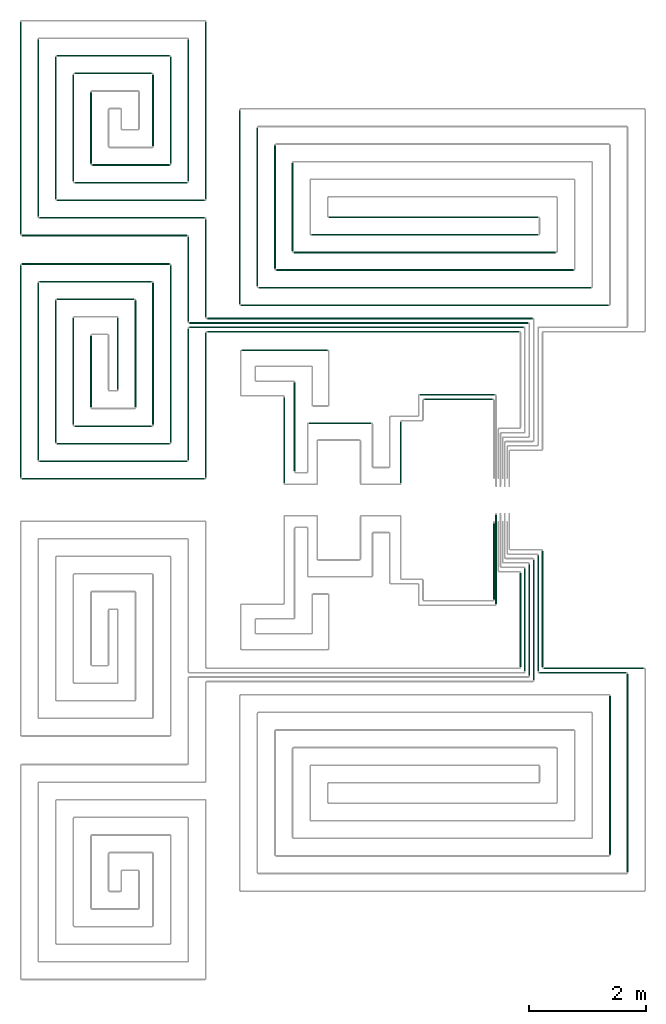
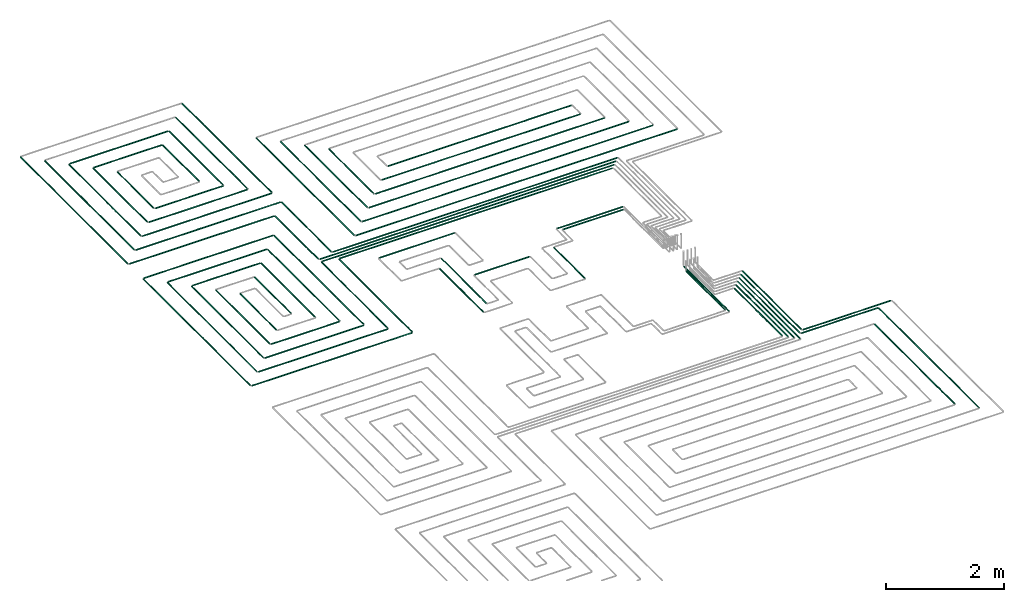
# One storey, part 2 of 12: 69 flow segments.
"""IFC2X3 building model written with IfcOpenShell, lengths in millimetres."""

from ifc_helpers import new_model, entity, si_unit, converted_unit, derived_unit, direction, frame, frame_2d, origin, origin_2d_with_axis, place, context, subcontext, project, spatial, circle, extrude, type_object, element, save


model = new_model("IFC2X3")

# Units and contexts
model_context = context("Model", 3, precision=0.01, world=origin(), true_north=direction((6.12303176911189e-17, 1.0)))
body_context = subcontext(model_context, "Body", "Model", "MODEL_VIEW")
ifc_project = project(units=[si_unit("LENGTHUNIT", "METRE", prefix="MILLI"), si_unit("AREAUNIT", "SQUARE_METRE"), si_unit("VOLUMEUNIT", "CUBIC_METRE"), converted_unit("PLANEANGLEUNIT", "DEGREE", entity("IfcRatioMeasure", 0.0174532925199433), si_unit("PLANEANGLEUNIT", "RADIAN"), dimensions=[0, 0, 0, 0, 0, 0, 0]), si_unit("MASSUNIT", "GRAM", prefix="KILO"), derived_unit("MASSDENSITYUNIT", [(si_unit("MASSUNIT", "GRAM", prefix="KILO"), 1), (si_unit("LENGTHUNIT", "METRE"), -3)]), si_unit("TIMEUNIT", "SECOND"), si_unit("FREQUENCYUNIT", "HERTZ"), si_unit("THERMODYNAMICTEMPERATUREUNIT", "DEGREE_CELSIUS"), derived_unit("THERMALTRANSMITTANCEUNIT", [(si_unit("MASSUNIT", "GRAM", prefix="KILO"), 1), (si_unit("THERMODYNAMICTEMPERATUREUNIT", "KELVIN"), -1), (si_unit("TIMEUNIT", "SECOND"), -3)]), derived_unit("VOLUMETRICFLOWRATEUNIT", [(si_unit("LENGTHUNIT", "METRE"), 3), (si_unit("TIMEUNIT", "SECOND"), -1)]), si_unit("ELECTRICCURRENTUNIT", "AMPERE"), si_unit("ELECTRICVOLTAGEUNIT", "VOLT"), si_unit("POWERUNIT", "WATT"), si_unit("FORCEUNIT", "NEWTON", prefix="KILO"), si_unit("ILLUMINANCEUNIT", "LUX"), si_unit("LUMINOUSFLUXUNIT", "LUMEN"), si_unit("LUMINOUSINTENSITYUNIT", "CANDELA"), derived_unit("USERDEFINED", [(si_unit("MASSUNIT", "GRAM", prefix="KILO"), -1), (si_unit("LENGTHUNIT", "METRE"), -2), (si_unit("TIMEUNIT", "SECOND"), 3), (si_unit("LUMINOUSFLUXUNIT", "LUMEN"), 1)]), derived_unit("LINEARVELOCITYUNIT", [(si_unit("LENGTHUNIT", "METRE"), 1), (si_unit("TIMEUNIT", "SECOND"), -1)]), si_unit("PRESSUREUNIT", "PASCAL"), derived_unit("USERDEFINED", [(si_unit("LENGTHUNIT", "METRE"), -2), (si_unit("MASSUNIT", "GRAM", prefix="KILO"), 1), (si_unit("TIMEUNIT", "SECOND"), -2)])], contexts=[model_context])

# Site, building, storey
site_placement = place(None, origin())
site = spatial("IfcSite", under=ifc_project, at=site_placement, CompositionType="ELEMENT")
building_placement = place(site_placement, origin())
building = spatial("IfcBuilding", under=site, at=building_placement, CompositionType="ELEMENT")
storey_placement = place(building_placement, frame((0.0, 0.0, 12000.0)))
storey = spatial("IfcBuildingStorey", under=building, at=storey_placement, Name="03 Level", CompositionType="ELEMENT", Elevation=12000.0)

# Flow segments
pipe_segment_type = type_object("IfcPipeSegmentType", PredefinedType="NOTDEFINED")
flow_segment_1_placement = place(storey_placement, frame((26623.6855494475, -71711.6450070283, -81.5952722359161)))
element("IfcFlowSegment", 1, at=flow_segment_1_placement, inside=storey, type_object=pipe_segment_type, context=body_context, shape_type="SweptSolid", body=[
    extrude(circle(Radius=10.0, at=origin_2d_with_axis()), frame((0.0, 11.5952722359136, 11.5952722359158), z_axis=(1.0, 0.0, 0.0), x_axis=(0.0, -1.0, 0.0)), (0.0, 0.0, 1.0), 1709.41153197237),
])
flow_segment_2_placement = place(storey_placement, frame((26548.6855494475, -71786.6450070283, -81.5952722359143)))
element("IfcFlowSegment", 2, at=flow_segment_2_placement, inside=storey, type_object=pipe_segment_type, context=body_context, shape_type="SweptSolid", body=[
    extrude(circle(Radius=10.0, at=origin_2d_with_axis()), frame((0.0, 11.5952722359136, 11.5952722359158), z_axis=(1.0, 0.0, 0.0), x_axis=(0.0, -1.0, 0.0)), (0.0, 0.0, 1.0), 1484.41153197236),
])
flow_segment_3_placement = place(storey_placement, frame((28041.5018091839, -75179.8436457933, -81.5952722359198)))
element("IfcFlowSegment", 3, at=flow_segment_3_placement, inside=storey, type_object=pipe_segment_type, context=body_context, shape_type="SweptSolid", body=[
    extrude(circle(Radius=10.0, at=frame_2d((-2.59888111031614e-11, 0.0), x_axis=(1.0, 0.0))), frame((11.5952722359526, 0.0, 11.5952722359158), z_axis=(0.0, 1.0, 0.0), x_axis=(-1.0, 0.0, 0.0)), (0.0, 0.0, 1.0), 3384.79391100087),
])
flow_segment_4_placement = place(storey_placement, frame((27741.5018091839, -74879.8436457933, -81.5952722359198)))
element("IfcFlowSegment", 4, at=flow_segment_4_placement, inside=storey, type_object=pipe_segment_type, context=body_context, shape_type="SweptSolid", body=[
    extrude(circle(Radius=10.0, at=origin_2d_with_axis()), frame((11.5952722359223, 0.0, 11.5952722359158), z_axis=(0.0, 1.0, 0.0), x_axis=(1.0, 0.0, 0.0)), (0.0, 0.0, 1.0), 2707.85893213088),
])
flow_segment_5_placement = place(storey_placement, frame((26442.0902772116, -71905.0497347924, -81.5952722359198)))
element("IfcFlowSegment", 5, at=flow_segment_5_placement, inside=storey, type_object=pipe_segment_type, context=body_context, shape_type="SweptSolid", body=[
    extrude(circle(Radius=10.0, at=origin_2d_with_axis()), frame((11.595272235918, 0.0, 11.5952722359158), z_axis=(0.0, 1.0, 0.0), x_axis=(-1.0, 0.0, 0.0)), (0.0, 0.0, 1.0), 2056.31014965248),
])
flow_segment_6_placement = place(storey_placement, frame((26367.0902772116, -71830.0497347924, -81.5952722359161)))
element("IfcFlowSegment", 6, at=flow_segment_6_placement, inside=storey, type_object=pipe_segment_type, context=body_context, shape_type="SweptSolid", body=[
    extrude(circle(Radius=10.0, at=origin_2d_with_axis()), frame((11.5952722359266, 0.0, 11.5952722359158), z_axis=(0.0, 1.0, 0.0), x_axis=(1.0, 0.0, 0.0)), (0.0, 0.0, 1.0), 1906.31014965249),
])
flow_segment_7_placement = place(storey_placement, frame((26292.0902772116, -71755.0497347924, -81.5952722359161)))
element("IfcFlowSegment", 7, at=flow_segment_7_placement, inside=storey, type_object=pipe_segment_type, context=body_context, shape_type="SweptSolid", body=[
    extrude(circle(Radius=10.0, at=origin_2d_with_axis()), frame((11.595272235918, 0.0, 11.5952722359158), z_axis=(0.0, 1.0, 0.0), x_axis=(1.0, 0.0, 0.0)), (0.0, 0.0, 1.0), 1756.31014965249),
])
flow_segment_8_placement = place(storey_placement, frame((26217.0902772116, -71680.0497347924, -81.5952722359198)))
element("IfcFlowSegment", 8, at=flow_segment_8_placement, inside=storey, type_object=pipe_segment_type, context=body_context, shape_type="SweptSolid", body=[
    extrude(circle(Radius=10.0, at=frame_2d((-4.33146851719357e-12, 0.0), x_axis=(1.0, 0.0))), frame((11.595272235918, 0.0, 11.5952722359158), z_axis=(0.0, 1.0, 0.0), x_axis=(-1.0, 0.0, 0.0)), (0.0, 0.0, 1.0), 1606.3101496525),
])
flow_segment_9_placement = place(storey_placement, frame((26592.0902772116, -71680.0497347924, -81.5952722359198)))
element("IfcFlowSegment", 9, at=flow_segment_9_placement, inside=storey, type_object=pipe_segment_type, context=body_context, shape_type="SweptSolid", body=[
    extrude(circle(Radius=10.0, at=frame_2d((4.33146851719357e-12, 0.0), x_axis=(1.0, 0.0))), frame((11.5952722359266, 0.0, 11.5952722359158), z_axis=(0.0, 1.0, 0.0), x_axis=(-1.0, 0.0, 0.0)), (0.0, 0.0, 1.0), 1981.31014965248),
])
flow_segment_10_placement = place(storey_placement, frame((26517.0902772116, -71755.0497347924, -81.5952722359161)))
element("IfcFlowSegment", 10, at=flow_segment_10_placement, inside=storey, type_object=pipe_segment_type, context=body_context, shape_type="SweptSolid", body=[
    extrude(circle(Radius=10.0, at=origin_2d_with_axis()), frame((11.5952722359266, 0.0, 11.5952722359158), z_axis=(0.0, 1.0, 0.0), x_axis=(1.0, 0.0, 0.0)), (0.0, 0.0, 1.0), 1981.31014965249),
])
flow_segment_11_placement = place(storey_placement, frame((25764.4416997349, -70531.3143518619, -81.5952722359252)))
element("IfcFlowSegment", 11, at=flow_segment_11_placement, inside=storey, type_object=pipe_segment_type, context=body_context, shape_type="SweptSolid", body=[
    extrude(circle(Radius=10.0, at=origin_2d_with_axis()), frame((11.595272235918, 0.0, 11.5952722359158), z_axis=(0.0, 1.0, 0.0), x_axis=(1.0, 0.0, 0.0)), (0.0, 0.0, 1.0), 1305.07476672193),
])
flow_segment_12_placement = place(storey_placement, frame((25799.4416997349, -70606.3143518619, -81.5952722359289)))
element("IfcFlowSegment", 12, at=flow_segment_12_placement, inside=storey, type_object=pipe_segment_type, context=body_context, shape_type="SweptSolid", body=[
    extrude(circle(Radius=10.0, at=frame_2d((0.0, -2.16573425859679e-12), x_axis=(1.0, 0.0))), frame((11.595272235918, 0.0, 11.5952722359136), z_axis=(0.0, 1.0, 0.0), x_axis=(1.0, 0.0, 0.0)), (0.0, 0.0, 1.0), 1520.07476672191),
])
flow_segment_13_placement = place(storey_placement, frame((20884.4386293741, -65974.0247077234, -81.5952722359198)))
element("IfcFlowSegment", 13, at=flow_segment_13_placement, inside=storey, type_object=pipe_segment_type, context=body_context, shape_type="SweptSolid", body=[
    extrude(circle(Radius=10.0, at=frame_2d((-8.66293703438714e-12, 0.0), x_axis=(1.0, 0.0))), frame((0.0, 11.595272235931, 11.5952722359158), z_axis=(1.0, 0.0, 0.0), x_axis=(0.0, 1.0, 0.0)), (0.0, 0.0, 1.0), 5324.24692007345),
])
flow_segment_14_placement = place(storey_placement, frame((20584.4386293741, -65899.0247077234, -81.5952722359161)))
element("IfcFlowSegment", 14, at=flow_segment_14_placement, inside=storey, type_object=pipe_segment_type, context=body_context, shape_type="SweptSolid", body=[
    extrude(circle(Radius=10.0, at=frame_2d((-8.66293703438714e-12, -2.16573425859679e-12), x_axis=(1.0, 0.0))), frame((0.0, 11.5952722359223, 11.595272235918), z_axis=(1.0, 0.0, 0.0), x_axis=(0.0, 1.0, 0.0)), (0.0, 0.0, 1.0), 5699.24692007345),
])
flow_segment_15_placement = place(storey_placement, frame((20584.4386293741, -65824.0247077234, -81.5952722359161)))
element("IfcFlowSegment", 15, at=flow_segment_15_placement, inside=storey, type_object=pipe_segment_type, context=body_context, shape_type="SweptSolid", body=[
    extrude(circle(Radius=10.0, at=frame_2d((8.66293703438714e-12, -2.16573425859679e-12), x_axis=(1.0, 0.0))), frame((0.0, 11.595272235905, 11.595272235918), z_axis=(1.0, 0.0, 0.0), x_axis=(0.0, 1.0, 0.0)), (0.0, 0.0, 1.0), 5774.24692007345),
])
flow_segment_16_placement = place(storey_placement, frame((20884.4386293741, -65749.0247077234, -81.5952722359161)))
element("IfcFlowSegment", 16, at=flow_segment_16_placement, inside=storey, type_object=pipe_segment_type, context=body_context, shape_type="SweptSolid", body=[
    extrude(circle(Radius=10.0, at=frame_2d((0.0, -2.16573425859679e-12), x_axis=(1.0, 0.0))), frame((0.0, 11.5952722359136, 11.595272235918), z_axis=(1.0, 0.0, 0.0), x_axis=(0.0, 1.0, 0.0)), (0.0, 0.0, 1.0), 5549.24692007344),
])
flow_segment_17_placement = place(storey_placement, frame((20552.8433571382, -65792.4294354875, -81.5952722359198)))
element("IfcFlowSegment", 17, at=flow_segment_17_placement, inside=storey, type_object=pipe_segment_type, context=body_context, shape_type="SweptSolid", body=[
    extrude(circle(Radius=10.0, at=origin_2d_with_axis()), frame((11.595272235918, 0.0, 11.5952722359158), z_axis=(0.0, 1.0, 0.0), x_axis=(1.0, 0.0, 0.0)), (0.0, 0.0, 1.0), 1451.18985034759),
])
flow_segment_18_placement = place(storey_placement, frame((20852.8433571382, -65717.4294354875, -81.5952722359198)))
element("IfcFlowSegment", 18, at=flow_segment_18_placement, inside=storey, type_object=pipe_segment_type, context=body_context, shape_type="SweptSolid", body=[
    extrude(circle(Radius=10.0, at=origin_2d_with_axis()), frame((11.5952722359223, 0.0, 11.5952722359158), z_axis=(0.0, 1.0, 0.0), x_axis=(1.0, 0.0, 0.0)), (0.0, 0.0, 1.0), 1676.18985034759),
])
flow_segment_19_placement = place(storey_placement, frame((24586.730888343, -67122.7600906539, -81.595272235927)))
element("IfcFlowSegment", 19, at=flow_segment_19_placement, inside=storey, type_object=pipe_segment_type, context=body_context, shape_type="SweptSolid", body=[
    extrude(circle(Radius=10.0, at=origin_2d_with_axis()), frame((0.0, 11.5952722359483, 11.5952722359158), z_axis=(1.0, 0.0, 0.0), x_axis=(0.0, -1.0, 0.0)), (0.0, 0.0, 1.0), 1169.30608362779),
])
flow_segment_20_placement = place(storey_placement, frame((20852.8433571382, -68451.2395851399, -81.5952722359198)))
element("IfcFlowSegment", 20, at=flow_segment_20_placement, inside=storey, type_object=pipe_segment_type, context=body_context, shape_type="SweptSolid", body=[
    extrude(circle(Radius=10.0, at=origin_2d_with_axis()), frame((11.5952722359439, 0.0, 11.5952722359158), z_axis=(0.0, 1.0, 0.0), x_axis=(1.0, 0.0, 0.0)), (0.0, 0.0, 1.0), 2468.81014965244),
])
flow_segment_21_placement = place(storey_placement, frame((20552.8433571382, -68151.2395851399, -81.5952722359198)))
element("IfcFlowSegment", 21, at=flow_segment_21_placement, inside=storey, type_object=pipe_segment_type, context=body_context, shape_type="SweptSolid", body=[
    extrude(circle(Radius=10.0, at=frame_2d((8.66293703438714e-12, 0.0), x_axis=(1.0, 0.0))), frame((11.5952722359266, 0.0, 11.5952722359158), z_axis=(0.0, 1.0, 0.0), x_axis=(-1.0, 0.0, 0.0)), (0.0, 0.0, 1.0), 2243.81014965244),
])
flow_segment_22_placement = place(storey_placement, frame((17725.6253473195, -68482.8348573758, -81.5952722359198)))
element("IfcFlowSegment", 22, at=flow_segment_22_placement, inside=storey, type_object=pipe_segment_type, context=body_context, shape_type="SweptSolid", body=[
    extrude(circle(Radius=10.0, at=frame_2d((1.73258740687743e-11, 0.0), x_axis=(1.0, 0.0))), frame((0.0, 11.595272235931, 11.5952722359158), z_axis=(1.0, 0.0, 0.0), x_axis=(0.0, 1.0, 0.0)), (0.0, 0.0, 1.0), 3118.81328205467),
])
flow_segment_23_placement = place(storey_placement, frame((18025.6253473195, -68182.8348573758, -81.5952722359198)))
element("IfcFlowSegment", 23, at=flow_segment_23_placement, inside=storey, type_object=pipe_segment_type, context=body_context, shape_type="SweptSolid", body=[
    extrude(circle(Radius=10.0, at=frame_2d((8.66293703438714e-12, 0.0), x_axis=(1.0, 0.0))), frame((0.0, 11.5952722359223, 11.5952722359158), z_axis=(1.0, 0.0, 0.0), x_axis=(0.0, 1.0, 0.0)), (0.0, 0.0, 1.0), 2518.81328205467),
])
flow_segment_24_placement = place(storey_placement, frame((17994.0300750835, -68151.2395851399, -81.5952722359198)))
element("IfcFlowSegment", 24, at=flow_segment_24_placement, inside=storey, type_object=pipe_segment_type, context=body_context, shape_type="SweptSolid", body=[
    extrude(circle(Radius=10.0, at=origin_2d_with_axis()), frame((11.5952722359439, 0.0, 11.5952722359158), z_axis=(0.0, 1.0, 0.0), x_axis=(1.0, 0.0, 0.0)), (0.0, 0.0, 1.0), 3023.35825128324),
])
flow_segment_25_placement = place(storey_placement, frame((17694.0300750835, -68451.2395851399, -81.5952722359216)))
element("IfcFlowSegment", 25, at=flow_segment_25_placement, inside=storey, type_object=pipe_segment_type, context=body_context, shape_type="SweptSolid", body=[
    extrude(circle(Radius=10.0, at=frame_2d((0.0, -2.16573425859679e-12), x_axis=(1.0, 0.0))), frame((11.5952722359374, 0.0, 11.5952722359136), z_axis=(0.0, 1.0, 0.0), x_axis=(1.0, 0.0, 0.0)), (0.0, 0.0, 1.0), 3623.35825128323),
])
flow_segment_26_placement = place(storey_placement, frame((18025.6253473194, -65119.4766060926, -81.5952722359198)))
element("IfcFlowSegment", 26, at=flow_segment_26_placement, inside=storey, type_object=pipe_segment_type, context=body_context, shape_type="SweptSolid", body=[
    extrude(circle(Radius=10.0, at=frame_2d((8.66293703438714e-12, 0.0), x_axis=(1.0, 0.0))), frame((0.0, 11.595272235905, 11.5952722359158), z_axis=(1.0, 0.0, 0.0), x_axis=(0.0, 1.0, 0.0)), (0.0, 0.0, 1.0), 1918.81328205468),
])
flow_segment_27_placement = place(storey_placement, frame((17725.6253473194, -64819.4766060926, -81.5952722359198)))
element("IfcFlowSegment", 27, at=flow_segment_27_placement, inside=storey, type_object=pipe_segment_type, context=body_context, shape_type="SweptSolid", body=[
    extrude(circle(Radius=10.0, at=frame_2d((8.66293703438714e-12, 0.0), x_axis=(1.0, 0.0))), frame((0.0, 11.5952722359136, 11.5952722359158), z_axis=(1.0, 0.0, 0.0), x_axis=(0.0, 1.0, 0.0)), (0.0, 0.0, 1.0), 2518.81328205467),
])
flow_segment_28_placement = place(storey_placement, frame((20252.8433571382, -67851.2395851399, -81.5952722359216)))
element("IfcFlowSegment", 28, at=flow_segment_28_placement, inside=storey, type_object=pipe_segment_type, context=body_context, shape_type="SweptSolid", body=[
    extrude(circle(Radius=10.0, at=frame_2d((0.0, -2.16573425859679e-12), x_axis=(1.0, 0.0))), frame((11.5952722359439, 0.0, 11.5952722359136), z_axis=(0.0, 1.0, 0.0), x_axis=(1.0, 0.0, 0.0)), (0.0, 0.0, 1.0), 3023.35825128323),
])
flow_segment_29_placement = place(storey_placement, frame((19952.8433571382, -67551.2395851399, -81.5952722359198)))
element("IfcFlowSegment", 29, at=flow_segment_29_placement, inside=storey, type_object=pipe_segment_type, context=body_context, shape_type="SweptSolid", body=[
    extrude(circle(Radius=10.0, at=frame_2d((1.29944055515807e-11, 0.0), x_axis=(1.0, 0.0))), frame((11.595272235931, 0.0, 11.5952722359158), z_axis=(0.0, 1.0, 0.0), x_axis=(-1.0, 0.0, 0.0)), (0.0, 0.0, 1.0), 2423.35825128325),
])
flow_segment_30_placement = place(storey_placement, frame((18325.6253473195, -67882.8348573759, -81.5952722359234)))
element("IfcFlowSegment", 30, at=flow_segment_30_placement, inside=storey, type_object=pipe_segment_type, context=body_context, shape_type="SweptSolid", body=[
    extrude(circle(Radius=10.0, at=origin_2d_with_axis()), frame((0.0, 11.5952722359136, 11.5952722359158), z_axis=(1.0, 0.0, 0.0), x_axis=(0.0, -1.0, 0.0)), (0.0, 0.0, 1.0), 1918.8132820547),
])
flow_segment_31_placement = place(storey_placement, frame((18625.6253473194, -67582.8348573759, -81.5952722359216)))
element("IfcFlowSegment", 31, at=flow_segment_31_placement, inside=storey, type_object=pipe_segment_type, context=body_context, shape_type="SweptSolid", body=[
    extrude(circle(Radius=10.0, at=frame_2d((8.66293703438714e-12, 0.0), x_axis=(1.0, 0.0))), frame((0.0, 11.5952722359136, 11.5952722359158), z_axis=(1.0, 0.0, 0.0), x_axis=(0.0, 1.0, 0.0)), (0.0, 0.0, 1.0), 1318.8132820547),
])
flow_segment_32_placement = place(storey_placement, frame((18594.0300750835, -67551.2395851399, -81.5952722359216)))
element("IfcFlowSegment", 32, at=flow_segment_32_placement, inside=storey, type_object=pipe_segment_type, context=body_context, shape_type="SweptSolid", body=[
    extrude(circle(Radius=10.0, at=frame_2d((0.0, -2.16573425859679e-12), x_axis=(1.0, 0.0))), frame((11.5952722359418, 0.0, 11.5952722359136), z_axis=(0.0, 1.0, 0.0), x_axis=(1.0, 0.0, 0.0)), (0.0, 0.0, 1.0), 1823.35825128327),
])
flow_segment_33_placement = place(storey_placement, frame((18294.0300750835, -67851.2395851399, -81.5952722359216)))
element("IfcFlowSegment", 33, at=flow_segment_33_placement, inside=storey, type_object=pipe_segment_type, context=body_context, shape_type="SweptSolid", body=[
    extrude(circle(Radius=10.0, at=frame_2d((0.0, -2.16573425859679e-12), x_axis=(1.0, 0.0))), frame((11.5952722359396, 0.0, 11.5952722359136), z_axis=(0.0, 1.0, 0.0), x_axis=(1.0, 0.0, 0.0)), (0.0, 0.0, 1.0), 2423.35825128326),
])
flow_segment_34_placement = place(storey_placement, frame((18325.6253473194, -65419.4766060926, -81.5952722359234)))
element("IfcFlowSegment", 34, at=flow_segment_34_placement, inside=storey, type_object=pipe_segment_type, context=body_context, shape_type="SweptSolid", body=[
    extrude(circle(Radius=10.0, at=frame_2d((8.66293703438714e-12, 0.0), x_axis=(1.0, 0.0))), frame((0.0, 11.5952722359136, 11.5952722359158), z_axis=(1.0, 0.0, 0.0), x_axis=(0.0, 1.0, 0.0)), (0.0, 0.0, 1.0), 1318.81328205471),
])
flow_segment_35_placement = place(storey_placement, frame((19652.8433571382, -67251.2395851399, -81.5952722359234)))
element("IfcFlowSegment", 35, at=flow_segment_35_placement, inside=storey, type_object=pipe_segment_type, context=body_context, shape_type="SweptSolid", body=[
    extrude(circle(Radius=10.0, at=origin_2d_with_axis()), frame((11.595272235931, 0.0, 11.5952722359158), z_axis=(0.0, 1.0, 0.0), x_axis=(1.0, 0.0, 0.0)), (0.0, 0.0, 1.0), 1823.35825128327),
])
flow_segment_36_placement = place(storey_placement, frame((19352.8433571382, -66951.2395851399, -81.5952722359234)))
element("IfcFlowSegment", 36, at=flow_segment_36_placement, inside=storey, type_object=pipe_segment_type, context=body_context, shape_type="SweptSolid", body=[
    extrude(circle(Radius=10.0, at=frame_2d((-2.16573425859679e-12, 0.0), x_axis=(1.0, 0.0))), frame((11.595272235931, 0.0, 11.5952722359158), z_axis=(0.0, 1.0, 0.0), x_axis=(1.0, 0.0, 0.0)), (0.0, 0.0, 1.0), 1223.35825128328),
])
flow_segment_37_placement = place(storey_placement, frame((18894.0300750835, -67251.23958514, -81.5952722359252)))
element("IfcFlowSegment", 37, at=flow_segment_37_placement, inside=storey, type_object=pipe_segment_type, context=body_context, shape_type="SweptSolid", body=[
    extrude(circle(Radius=10.0, at=origin_2d_with_axis()), frame((11.5952722359374, 0.0, 11.5952722359158), z_axis=(0.0, 1.0, 0.0), x_axis=(1.0, 0.0, 0.0)), (0.0, 0.0, 1.0), 1223.35825128332),
])
flow_segment_38_placement = place(storey_placement, frame((20852.8433571382, -63701.2395851399, -81.5952722359198)))
element("IfcFlowSegment", 38, at=flow_segment_38_placement, inside=storey, type_object=pipe_segment_type, context=body_context, shape_type="SweptSolid", body=[
    extrude(circle(Radius=10.0, at=origin_2d_with_axis()), frame((11.5952722359439, 0.0, 11.5952722359158), z_axis=(0.0, 1.0, 0.0), x_axis=(1.0, 0.0, 0.0)), (0.0, 0.0, 1.0), 3023.35825128325),
])
flow_segment_39_placement = place(storey_placement, frame((20552.8433571382, -63401.2395851399, -81.5952722359198)))
element("IfcFlowSegment", 39, at=flow_segment_39_placement, inside=storey, type_object=pipe_segment_type, context=body_context, shape_type="SweptSolid", body=[
    extrude(circle(Radius=10.0, at=frame_2d((8.66293703438714e-12, 0.0), x_axis=(1.0, 0.0))), frame((11.5952722359266, 0.0, 11.5952722359158), z_axis=(0.0, 1.0, 0.0), x_axis=(-1.0, 0.0, 0.0)), (0.0, 0.0, 1.0), 2423.35825128326),
])
flow_segment_40_placement = place(storey_placement, frame((17994.0300750835, -64001.2395851399, -81.5952722359216)))
element("IfcFlowSegment", 40, at=flow_segment_40_placement, inside=storey, type_object=pipe_segment_type, context=body_context, shape_type="SweptSolid", body=[
    extrude(circle(Radius=10.0, at=frame_2d((0.0, -2.16573425859679e-12), x_axis=(1.0, 0.0))), frame((11.5952722359526, 0.0, 11.5952722359136), z_axis=(0.0, 1.0, 0.0), x_axis=(1.0, 0.0, 0.0)), (0.0, 0.0, 1.0), 3023.35825128327),
])
flow_segment_41_placement = place(storey_placement, frame((17694.0300750835, -64301.2395851399, -81.5952722359234)))
element("IfcFlowSegment", 41, at=flow_segment_41_placement, inside=storey, type_object=pipe_segment_type, context=body_context, shape_type="SweptSolid", body=[
    extrude(circle(Radius=10.0, at=origin_2d_with_axis()), frame((11.5952722359483, 0.0, 11.5952722359158), z_axis=(0.0, 1.0, 0.0), x_axis=(1.0, 0.0, 0.0)), (0.0, 0.0, 1.0), 3623.35825128325),
])
flow_segment_42_placement = place(storey_placement, frame((20252.8433571382, -63101.23958514, -81.5952722359234)))
element("IfcFlowSegment", 42, at=flow_segment_42_placement, inside=storey, type_object=pipe_segment_type, context=body_context, shape_type="SweptSolid", body=[
    extrude(circle(Radius=10.0, at=origin_2d_with_axis()), frame((11.5952722359439, 0.0, 11.5952722359158), z_axis=(0.0, 1.0, 0.0), x_axis=(1.0, 0.0, 0.0)), (0.0, 0.0, 1.0), 1823.35825128329),
])
flow_segment_43_placement = place(storey_placement, frame((19952.8433571382, -62801.2395851399, -81.5952722359198)))
element("IfcFlowSegment", 43, at=flow_segment_43_placement, inside=storey, type_object=pipe_segment_type, context=body_context, shape_type="SweptSolid", body=[
    extrude(circle(Radius=10.0, at=frame_2d((8.66293703438714e-12, 0.0), x_axis=(1.0, 0.0))), frame((11.5952722359266, 0.0, 11.5952722359158), z_axis=(0.0, 1.0, 0.0), x_axis=(-1.0, 0.0, 0.0)), (0.0, 0.0, 1.0), 1223.35825128325),
])
flow_segment_44_placement = place(storey_placement, frame((18594.0300750835, -63401.23958514, -81.595272235927)))
element("IfcFlowSegment", 44, at=flow_segment_44_placement, inside=storey, type_object=pipe_segment_type, context=body_context, shape_type="SweptSolid", body=[
    extrude(circle(Radius=10.0, at=frame_2d((1.51601398101775e-11, 0.0), x_axis=(1.0, 0.0))), frame((11.595272235931, 0.0, 11.5952722359158), z_axis=(0.0, 1.0, 0.0), x_axis=(-1.0, 0.0, 0.0)), (0.0, 0.0, 1.0), 1823.35825128331),
])
flow_segment_45_placement = place(storey_placement, frame((18294.0300750835, -63701.23958514, -81.595272235927)))
element("IfcFlowSegment", 45, at=flow_segment_45_placement, inside=storey, type_object=pipe_segment_type, context=body_context, shape_type="SweptSolid", body=[
    extrude(circle(Radius=10.0, at=frame_2d((1.51601398101775e-11, 0.0), x_axis=(1.0, 0.0))), frame((11.5952722359331, 0.0, 11.5952722359158), z_axis=(0.0, 1.0, 0.0), x_axis=(-1.0, 0.0, 0.0)), (0.0, 0.0, 1.0), 2423.35825128329),
])
flow_segment_46_placement = place(storey_placement, frame((18894.0300750835, -63101.23958514, -81.5952722359252)))
element("IfcFlowSegment", 46, at=flow_segment_46_placement, inside=storey, type_object=pipe_segment_type, context=body_context, shape_type="SweptSolid", body=[
    extrude(circle(Radius=10.0, at=origin_2d_with_axis()), frame((11.5952722359504, 0.0, 11.5952722359158), z_axis=(0.0, 1.0, 0.0), x_axis=(1.0, 0.0, 0.0)), (0.0, 0.0, 1.0), 1223.35825128335),
])
flow_segment_47_placement = place(storey_placement, frame((17725.6253473195, -64332.8348573759, -81.5952722359161)))
element("IfcFlowSegment", 47, at=flow_segment_47_placement, inside=storey, type_object=pipe_segment_type, context=body_context, shape_type="SweptSolid", body=[
    extrude(circle(Radius=10.0, at=frame_2d((2.59888111031614e-11, -2.16573425859679e-12), x_axis=(1.0, 0.0))), frame((0.0, 11.5952722359396, 11.595272235918), z_axis=(1.0, 0.0, 0.0), x_axis=(0.0, 1.0, 0.0)), (0.0, 0.0, 1.0), 2818.81328205464),
])
flow_segment_48_placement = place(storey_placement, frame((18025.6253473195, -64032.8348573759, -81.5952722359198)))
element("IfcFlowSegment", 48, at=flow_segment_48_placement, inside=storey, type_object=pipe_segment_type, context=body_context, shape_type="SweptSolid", body=[
    extrude(circle(Radius=10.0, at=frame_2d((2.59888111031614e-11, 0.0), x_axis=(1.0, 0.0))), frame((0.0, 11.5952722359396, 11.5952722359158), z_axis=(1.0, 0.0, 0.0), x_axis=(0.0, 1.0, 0.0)), (0.0, 0.0, 1.0), 2818.81328205464),
])
flow_segment_49_placement = place(storey_placement, frame((18325.6253473195, -63732.8348573759, -81.5952722359198)))
element("IfcFlowSegment", 49, at=flow_segment_49_placement, inside=storey, type_object=pipe_segment_type, context=body_context, shape_type="SweptSolid", body=[
    extrude(circle(Radius=10.0, at=frame_2d((1.73258740687743e-11, 0.0), x_axis=(1.0, 0.0))), frame((0.0, 11.595272235931, 11.5952722359158), z_axis=(1.0, 0.0, 0.0), x_axis=(0.0, 1.0, 0.0)), (0.0, 0.0, 1.0), 2518.8132820547),
])
flow_segment_50_placement = place(storey_placement, frame((18625.6253473194, -63432.8348573759, -81.5952722359198)))
element("IfcFlowSegment", 50, at=flow_segment_50_placement, inside=storey, type_object=pipe_segment_type, context=body_context, shape_type="SweptSolid", body=[
    extrude(circle(Radius=10.0, at=frame_2d((1.73258740687743e-11, 0.0), x_axis=(1.0, 0.0))), frame((0.0, 11.595272235931, 11.5952722359158), z_axis=(1.0, 0.0, 0.0), x_axis=(0.0, 1.0, 0.0)), (0.0, 0.0, 1.0), 1918.8132820547),
])
flow_segment_51_placement = place(storey_placement, frame((18625.6253473194, -61569.4766060926, -81.5952722359216)))
element("IfcFlowSegment", 51, at=flow_segment_51_placement, inside=storey, type_object=pipe_segment_type, context=body_context, shape_type="SweptSolid", body=[
    extrude(circle(Radius=10.0, at=origin_2d_with_axis()), frame((0.0, 11.5952722359136, 11.5952722359158), z_axis=(1.0, 0.0, 0.0), x_axis=(0.0, 1.0, 0.0)), (0.0, 0.0, 1.0), 1318.81328205473),
])
flow_segment_52_placement = place(storey_placement, frame((18325.6253473194, -61269.4766060926, -81.5952722359216)))
element("IfcFlowSegment", 52, at=flow_segment_52_placement, inside=storey, type_object=pipe_segment_type, context=body_context, shape_type="SweptSolid", body=[
    extrude(circle(Radius=10.0, at=origin_2d_with_axis()), frame((0.0, 11.5952722359136, 11.5952722359158), z_axis=(1.0, 0.0, 0.0), x_axis=(0.0, 1.0, 0.0)), (0.0, 0.0, 1.0), 1918.81328205471),
])
flow_segment_53_placement = place(storey_placement, frame((18925.6253473194, -63132.8348573759, -81.5952722359234)))
element("IfcFlowSegment", 53, at=flow_segment_53_placement, inside=storey, type_object=pipe_segment_type, context=body_context, shape_type="SweptSolid", body=[
    extrude(circle(Radius=10.0, at=frame_2d((8.66293703438714e-12, 0.0), x_axis=(1.0, 0.0))), frame((0.0, 11.5952722359136, 11.5952722359158), z_axis=(1.0, 0.0, 0.0), x_axis=(0.0, 1.0, 0.0)), (0.0, 0.0, 1.0), 1318.81328205473),
])
flow_segment_54_placement = place(storey_placement, frame((21730.6562350407, -65190.4944566176, -81.595272235927)))
element("IfcFlowSegment", 54, at=flow_segment_54_placement, inside=storey, type_object=pipe_segment_type, context=body_context, shape_type="SweptSolid", body=[
    extrude(circle(Radius=10.0, at=origin_2d_with_axis()), frame((11.5952722359699, 0.0, 11.5952722359158), z_axis=(0.0, 1.0, 0.0), x_axis=(1.0, 0.0, 0.0)), (0.0, 0.0, 1.0), 2707.85893213097),
])
flow_segment_55_placement = place(storey_placement, frame((21430.6562350407, -65490.4944566176, -81.595272235927)))
element("IfcFlowSegment", 55, at=flow_segment_55_placement, inside=storey, type_object=pipe_segment_type, context=body_context, shape_type="SweptSolid", body=[
    extrude(circle(Radius=10.0, at=origin_2d_with_axis()), frame((11.5952722359526, 0.0, 11.5952722359158), z_axis=(0.0, 1.0, 0.0), x_axis=(1.0, 0.0, 0.0)), (0.0, 0.0, 1.0), 3307.85893213096),
])
flow_segment_56_placement = place(storey_placement, frame((22330.6562350407, -64590.4944566176, -81.5952722359325)))
element("IfcFlowSegment", 56, at=flow_segment_56_placement, inside=storey, type_object=pipe_segment_type, context=body_context, shape_type="SweptSolid", body=[
    extrude(circle(Radius=10.0, at=origin_2d_with_axis()), frame((11.5952722359526, 0.0, 11.5952722359158), z_axis=(0.0, 1.0, 0.0), x_axis=(1.0, 0.0, 0.0)), (0.0, 0.0, 1.0), 1507.858932131),
])
flow_segment_57_placement = place(storey_placement, frame((22030.6562350407, -64890.4944566176, -81.5952722359325)))
element("IfcFlowSegment", 57, at=flow_segment_57_placement, inside=storey, type_object=pipe_segment_type, context=body_context, shape_type="SweptSolid", body=[
    extrude(circle(Radius=10.0, at=origin_2d_with_axis()), frame((11.5952722359483, 0.0, 11.5952722359158), z_axis=(0.0, 1.0, 0.0), x_axis=(1.0, 0.0, 0.0)), (0.0, 0.0, 1.0), 2107.85893213099),
])
flow_segment_58_placement = place(storey_placement, frame((21462.2515072767, -65522.0897288535, -81.595272235927)))
element("IfcFlowSegment", 58, at=flow_segment_58_placement, inside=storey, type_object=pipe_segment_type, context=body_context, shape_type="SweptSolid", body=[
    extrude(circle(Radius=10.0, at=frame_2d((6.064055924071e-11, 0.0), x_axis=(1.0, 0.0))), frame((0.0, 11.5952722359743, 11.5952722359158), z_axis=(1.0, 0.0, 0.0), x_axis=(0.0, 1.0, 0.0)), (0.0, 0.0, 1.0), 6270.84557414324),
])
flow_segment_59_placement = place(storey_placement, frame((21762.2515072767, -65222.0897288535, -81.5952722359161)))
element("IfcFlowSegment", 59, at=flow_segment_59_placement, inside=storey, type_object=pipe_segment_type, context=body_context, shape_type="SweptSolid", body=[
    extrude(circle(Radius=10.0, at=frame_2d((5.19776222063229e-11, -2.16573425859679e-12), x_axis=(1.0, 0.0))), frame((0.0, 11.5952722359656, 11.595272235918), z_axis=(1.0, 0.0, 0.0), x_axis=(0.0, 1.0, 0.0)), (0.0, 0.0, 1.0), 5670.84557414323),
])
flow_segment_60_placement = place(storey_placement, frame((22062.2515072766, -64922.0897288535, -81.5952722359252)))
element("IfcFlowSegment", 60, at=flow_segment_60_placement, inside=storey, type_object=pipe_segment_type, context=body_context, shape_type="SweptSolid", body=[
    extrude(circle(Radius=10.0, at=frame_2d((3.46517481375486e-11, -2.16573425859679e-12), x_axis=(1.0, 0.0))), frame((0.0, 11.5952722359483, 11.595272235918), z_axis=(1.0, 0.0, 0.0), x_axis=(0.0, 1.0, 0.0)), (0.0, 0.0, 1.0), 5070.84557414326),
])
flow_segment_61_placement = place(storey_placement, frame((22362.2515072766, -64622.0897288535, -81.5952722359216)))
element("IfcFlowSegment", 61, at=flow_segment_61_placement, inside=storey, type_object=pipe_segment_type, context=body_context, shape_type="SweptSolid", body=[
    extrude(circle(Radius=10.0, at=frame_2d((2.59888111031614e-11, 0.0), x_axis=(1.0, 0.0))), frame((0.0, 11.5952722359483, 11.5952722359158), z_axis=(1.0, 0.0, 0.0), x_axis=(0.0, 1.0, 0.0)), (0.0, 0.0, 1.0), 4470.84557414325),
])
flow_segment_62_placement = place(storey_placement, frame((22662.2515072766, -64322.0897288535, -81.595272235927)))
element("IfcFlowSegment", 62, at=flow_segment_62_placement, inside=storey, type_object=pipe_segment_type, context=body_context, shape_type="SweptSolid", body=[
    extrude(circle(Radius=10.0, at=frame_2d((3.46517481375486e-11, 0.0), x_axis=(1.0, 0.0))), frame((0.0, 11.5952722359483, 11.5952722359158), z_axis=(1.0, 0.0, 0.0), x_axis=(0.0, 1.0, 0.0)), (0.0, 0.0, 1.0), 3870.84557414328),
])
flow_segment_63_placement = place(storey_placement, frame((22962.2515072766, -64022.0897288535, -81.595272235927)))
element("IfcFlowSegment", 63, at=flow_segment_63_placement, inside=storey, type_object=pipe_segment_type, context=body_context, shape_type="SweptSolid", body=[
    extrude(circle(Radius=10.0, at=frame_2d((5.19776222063229e-11, 0.0), x_axis=(1.0, 0.0))), frame((0.0, 11.5952722359656, 11.5952722359158), z_axis=(1.0, 0.0, 0.0), x_axis=(0.0, 1.0, 0.0)), (0.0, 0.0, 1.0), 3570.8455741433),
])
flow_segment_64_placement = place(storey_placement, frame((24174.4137837032, -68544.4393916874, -81.5952722359289)))
element("IfcFlowSegment", 64, at=flow_segment_64_placement, inside=storey, type_object=pipe_segment_type, context=body_context, shape_type="SweptSolid", body=[
    extrude(circle(Radius=10.0, at=frame_2d((0.0, -2.16573425859679e-12), x_axis=(1.0, 0.0))), frame((11.5952722359786, 0.0, 11.5952722359136), z_axis=(0.0, 1.0, 0.0), x_axis=(1.0, 0.0, 0.0)), (0.0, 0.0, 1.0), 1044.42186360162),
])
flow_segment_65_placement = place(storey_placement, frame((21476.9829033853, -66291.7494840976, -81.5952722359289)))
element("IfcFlowSegment", 65, at=flow_segment_65_placement, inside=storey, type_object=pipe_segment_type, context=body_context, shape_type="SweptSolid", body=[
    extrude(circle(Radius=10.0, at=frame_2d((8.66293703438714e-12, 0.0), x_axis=(1.0, 0.0))), frame((0.0, 11.595272235905, 11.5952722359158), z_axis=(1.0, 0.0, 0.0), x_axis=(0.0, 1.0, 0.0)), (0.0, 0.0, 1.0), 1461.77751147482),
])
flow_segment_66_placement = place(storey_placement, frame((22190.153709968, -68544.4393916874, -81.5952722359289)))
element("IfcFlowSegment", 66, at=flow_segment_66_placement, inside=storey, type_object=pipe_segment_type, context=body_context, shape_type="SweptSolid", body=[
    extrude(circle(Radius=10.0, at=frame_2d((0.0, -2.16573425859679e-12), x_axis=(1.0, 0.0))), frame((11.5952722359266, 0.0, 11.5952722359136), z_axis=(0.0, 1.0, 0.0), x_axis=(1.0, 0.0, 0.0)), (0.0, 0.0, 1.0), 1468.19980654745),
])
flow_segment_67_placement = place(storey_placement, frame((22365.153709968, -68344.4393916874, -81.5952722359234)))
element("IfcFlowSegment", 67, at=flow_segment_67_placement, inside=storey, type_object=pipe_segment_type, context=body_context, shape_type="SweptSolid", body=[
    extrude(circle(Radius=10.0, at=origin_2d_with_axis()), frame((11.5952722359266, 0.0, 11.5952722359158), z_axis=(0.0, 1.0, 0.0), x_axis=(1.0, 0.0, 0.0)), (0.0, 0.0, 1.0), 1518.19980654744),
])
flow_segment_68_placement = place(storey_placement, frame((24511.730888343, -67047.7600906539, -81.5952722359252)))
element("IfcFlowSegment", 68, at=flow_segment_68_placement, inside=storey, type_object=pipe_segment_type, context=body_context, shape_type="SweptSolid", body=[
    extrude(circle(Radius=10.0, at=origin_2d_with_axis()), frame((0.0, 11.5952722359136, 11.5952722359158), z_axis=(1.0, 0.0, 0.0), x_axis=(0.0, -1.0, 0.0)), (0.0, 0.0, 1.0), 1279.3060836278),
])
flow_segment_69_placement = place(storey_placement, frame((22622.1485075651, -67532.8348573758, -81.5952722359343)))
element("IfcFlowSegment", 69, at=flow_segment_69_placement, inside=storey, type_object=pipe_segment_type, context=body_context, shape_type="SweptSolid", body=[
    extrude(circle(Radius=10.0, at=frame_2d((0.0, -2.16573425859679e-12), x_axis=(1.0, 0.0))), frame((0.0, 11.595272235931, 11.595272235918), z_axis=(1.0, 0.0, 0.0), x_axis=(0.0, 1.0, 0.0)), (0.0, 0.0, 1.0), 1062.80764523384),
])

save(model, "model.ifc")
